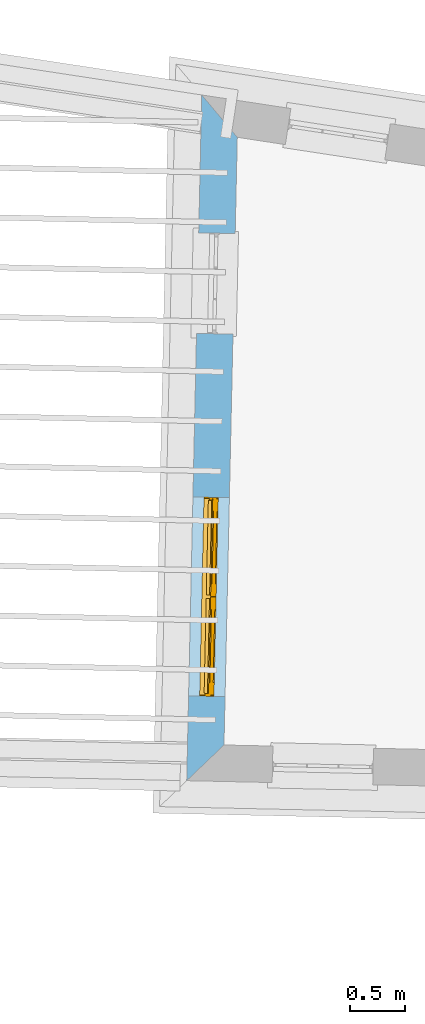
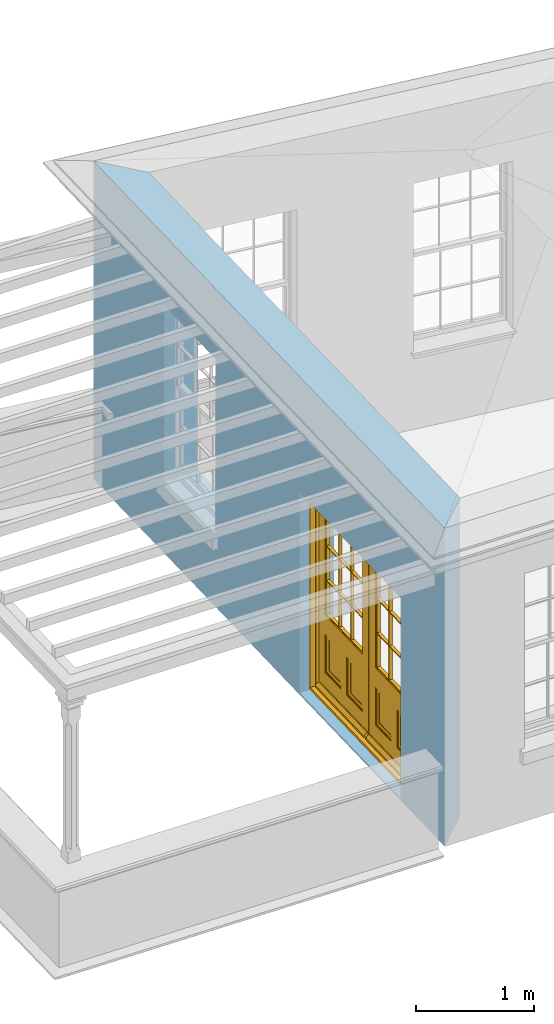
# One storey, part 4 of 12: 1 door, 2 openings, plus 1 element that does not belong to this part.
"""IFC2X3 building model written with IfcOpenShell, lengths in metres."""

from ifc_helpers import new_model, si_unit, frame, origin, place, context, subcontext, project, spatial, polyline, outline, extrude, faceted_brep, material, layer, layer_set, layer_usage, element, fill, save


model = new_model("IFC2X3")

# Units and contexts
model_context = context("Model", 3, world=origin())
body_context = subcontext(model_context, "Body", "Model", "MODEL_VIEW")
ifc_project = project(units=[si_unit("PLANEANGLEUNIT", "RADIAN"), si_unit("MASSUNIT", "GRAM", prefix="KILO"), si_unit("FORCEUNIT", "NEWTON", prefix="KILO"), si_unit("LENGTHUNIT", "METRE")], contexts=[model_context])

# Site, building, storey
site_placement = place(None, origin())
site = spatial("IfcSite", under=ifc_project, at=site_placement, CompositionType="ELEMENT")
building_placement = place(None, origin())
building = spatial("IfcBuilding", under=site, at=building_placement, Name="Building plot-18", CompositionType="ELEMENT")
storey_placement = place(None, frame((0.0, 0.0, 9.9)))
storey = spatial("IfcBuildingStorey", under=building, at=storey_placement, Name="Floor 2", CompositionType="ELEMENT", Elevation=9.9)

# Wall, openings, door
ifc_material = material(Name="Masonry")
ifc_layer = layer(ifc_material, 0.33, ventilated=False)
ifc_layer_set = layer_set([ifc_layer], Name="My Wall")
ifc_layer_usage = layer_usage(ifc_layer_set, "AXIS2", "NEGATIVE", 0.08)
wall_placement = place(storey_placement, origin())
wall = element("IfcWallStandardCase", 1, at=wall_placement, inside=storey, material=ifc_layer_usage, Name="exterior", context=body_context, shape_type="SweptSolid", body=[
    extrude(outline(polyline([(90.2260155594004, 26.2254654944291), (89.9043108567451, 26.6083343363116), (89.7686586524696, 20.406326207039), (90.1057958794453, 20.7290311654569), (90.2260155594004, 26.2254654944291)])), origin(), (0.0, 0.0, 1.0), 3.3),
])
opening_1_placement = place(storey_placement, frame((0.0, 0.0, 0.75)))
element("IfcOpeningElement", 2, at=opening_1_placement, cuts=wall, Name="Opening", ObjectType="Opening", context=body_context, shape_type="SweptSolid", body=[
    extrude(outline(polyline([(89.8770456128179, 25.3617695245838), (89.8571465758663, 24.451987117451), (90.1870676685628, 24.4447709831718), (90.2069667055144, 25.3545533903047), (89.8770456128179, 25.3617695245838)])), origin(), (0.0, 0.0, 1.0), 1.82),
])
opening_2_placement = place(storey_placement, frame((0.0, 0.0, 0.0199999999999996)))
opening_2 = element("IfcOpeningElement", 3, at=opening_2_placement, cuts=wall, Name="Opening", ObjectType="Opening", context=body_context, shape_type="SweptSolid", body=[
    extrude(outline(polyline([(89.8247960115718, 22.9729218577882), (89.7854352791401, 21.1733522612618), (90.1153563718366, 21.1661361269826), (90.1547171042684, 22.9657057235091), (89.8247960115718, 22.9729218577882)])), origin(), (0.0, 0.0, 1.0), 2.08),
])
door_placement = place(storey_placement, frame((90.0747362333116, 22.9674550893949, 0.0199999999999996), z_axis=(0.0, 0.0, 1.0), x_axis=(-0.03936073243176, -1.79956959652647, 0.0)))
door = element("IfcDoor", 4, at=door_placement, inside=storey, Name="living outside door", OverallHeight=2.08, OverallWidth=1.8, context=body_context, shape_type="Brep", held_by="IfcProductRepresentation", body=[
    faceted_brep([(0.545, -0.055, 0.265), (0.745, -0.055, 0.265), (0.745, -0.05, 0.265), (0.545, -0.05, 0.265), (0.745, -0.05, 0.58), (0.545, -0.05, 0.58), (0.545, -0.055, 0.58), (0.515, -0.06, 0.235), (0.775, -0.06, 0.235), (0.745, -0.055, 0.58), (0.515, -0.06, 0.61), (0.515, -0.065, 0.235), (0.775, -0.065, 0.235), (0.775, -0.06, 0.61), (0.515, -0.065, 0.61), (0.785, -0.065, 0.225), (0.505, -0.065, 0.225), (0.775, -0.065, 0.61), (0.505, -0.065, 0.62), (0.785, -0.065, 0.62), (0.505, -0.07, 0.225), (0.785, -0.07, 0.225), (0.505, -0.07, 0.62), (0.785, -0.07, 0.62), (0.883, -0.07, 0.075), (0.898, -0.07, 0.075), (0.405, -0.07, 0.62), (0.405, -0.07, 0.225), (0.027, -0.07, 0.075), (0.785, -0.07, 0.82), (0.125, -0.07, 0.82), (0.405, -0.065, 0.62), (0.405, -0.065, 0.225), (0.898, -0.07, 2.068), (0.027, -0.08, 0.075), (0.883, -0.08, 0.075), (0.125, -0.07, 0.225), (0.012, -0.07, 0.075), (0.785, -0.06, 0.82), (0.125, -0.06, 0.82), (0.125, -0.07, 0.62), (0.125, -0.065, 0.62), (0.395, -0.065, 0.61), (0.395, -0.065, 0.235), (0.125, -0.065, 0.225), (0.785, -0.07, 1.895), (0.027, -0.11, 0.045), (0.883, -0.11, 0.045), (0.558333, -0.06, 0.83), (0.351667, -0.06, 0.83), (0.125, -0.07, 1.895), (0.125, -0.06, 1.895), (0.785, -0.06, 1.895), (0.012, -0.07, 2.068), (0.135, -0.065, 0.61), (0.395, -0.06, 0.61), (0.395, -0.06, 0.235), (0.135, -0.065, 0.235), (0.027, -0.11, 0.027), (0.883, -0.11, 0.027), (0.568333, -0.06, 0.83), (0.558333, -0.03, 0.83), (0.351667, -0.03, 0.83), (0.341667, -0.06, 0.83), (0.135, -0.06, 1.185), (0.135, -0.06, 1.53), (0.775, -0.06, 1.53), (0.775, -0.06, 1.185), (0.135, -0.06, 0.61), (0.365, -0.055, 0.58), (0.365, -0.055, 0.265), (0.135, -0.06, 0.235), (0.568333, -0.06, 1.175), (0.558333, -0.06, 1.175), (0.775, -0.06, 0.83), (0.558333, -0.03, 1.175), (0.785, -0.03, 0.82), (0.125, -0.03, 0.82), (0.351667, -0.03, 1.175), (0.351667, -0.06, 1.175), (0.341667, -0.06, 1.175), (0.135, -0.06, 0.83), (0.135, -0.06, 1.175), (0.135, -0.03, 1.185), (0.135, -0.03, 1.53), (0.135, -0.06, 1.54), (0.351667, -0.06, 1.885), (0.558333, -0.06, 1.885), (0.775, -0.03, 1.53), (0.775, -0.03, 1.185), (0.775, -0.06, 1.175), (0.775, -0.06, 1.54), (0.165, -0.055, 0.58), (0.365, -0.05, 0.58), (0.365, -0.05, 0.265), (0.165, -0.055, 0.265), (0.568333, -0.03, 0.83), (0.568333, -0.03, 1.175), (0.568333, -0.06, 1.185), (0.558333, -0.06, 1.185), (0.775, -0.03, 0.83), (0.785, -0.02, 0.82), (0.125, -0.02, 0.82), (0.341667, -0.03, 0.83), (0.341667, -0.03, 1.175), (0.351667, -0.06, 1.185), (0.341667, -0.06, 1.185), (0.135, -0.03, 0.83), (0.341667, -0.03, 1.185), (0.125, -0.03, 1.895), (0.341667, -0.03, 1.53), (0.341667, -0.06, 1.53), (0.135, -0.06, 1.885), (0.341667, -0.06, 1.54), (0.341667, -0.06, 1.885), (0.558333, -0.03, 1.885), (0.351667, -0.03, 1.885), (0.568333, -0.06, 1.885), (0.785, -0.03, 1.895), (0.568333, -0.03, 1.185), (0.568333, -0.06, 1.53), (0.568333, -0.03, 1.53), (0.568333, -0.06, 1.54), (0.775, -0.06, 1.885), (0.165, -0.05, 0.58), (0.165, -0.05, 0.265), (0.775, -0.03, 1.175), (0.558333, -0.06, 1.53), (0.351667, -0.03, 1.185), (0.558333, -0.03, 1.185), (0.505, -0.02, 0.62), (0.405, -0.02, 0.62), (0.125, -0.02, 1.895), (0.785, -0.02, 1.895), (0.351667, -0.06, 1.53), (0.135, -0.03, 1.175), (0.135, -0.03, 1.54), (0.341667, -0.03, 1.54), (0.135, -0.03, 1.885), (0.351667, -0.06, 1.54), (0.558333, -0.03, 1.54), (0.558333, -0.06, 1.54), (0.351667, -0.03, 1.54), (0.775, -0.03, 1.54), (0.568333, -0.03, 1.54), (0.775, -0.03, 1.885), (0.558333, -0.03, 1.53), (0.405, -0.02, 0.225), (0.505, -0.02, 0.225), (0.125, -0.02, 0.62), (0.785, -0.02, 0.62), (0.012, -0.02, 2.068), (0.898, -0.02, 2.068), (0.351667, -0.03, 1.53), (0.341667, -0.03, 1.885), (0.568333, -0.03, 1.885), (0.405, -0.025, 0.225), (0.405, -0.025, 0.62), (0.505, -0.025, 0.62), (0.505, -0.025, 0.225), (0.898, -0.02, 0.027), (0.012, -0.02, 0.027), (0.125, -0.025, 0.62), (0.785, -0.025, 0.62), (0.395, -0.025, 0.235), (0.395, -0.025, 0.61), (0.125, -0.02, 0.225), (0.125, -0.025, 0.225), (0.515, -0.025, 0.61), (0.515, -0.025, 0.235), (0.785, -0.02, 0.225), (0.785, -0.025, 0.225), (0.135, -0.025, 0.61), (0.775, -0.025, 0.61), (0.135, -0.025, 0.235), (0.395, -0.03, 0.235), (0.395, -0.03, 0.61), (0.515, -0.03, 0.61), (0.515, -0.03, 0.235), (0.775, -0.025, 0.235), (0.135, -0.03, 0.61), (0.775, -0.03, 0.61), (0.135, -0.03, 0.235), (0.365, -0.035, 0.265), (0.365, -0.035, 0.58), (0.545, -0.035, 0.58), (0.545, -0.035, 0.265), (0.775, -0.03, 0.235), (0.165, -0.035, 0.58), (0.745, -0.035, 0.58), (0.165, -0.035, 0.265), (0.365, -0.04, 0.58), (0.365, -0.04, 0.265), (0.545, -0.04, 0.58), (0.545, -0.04, 0.265), (0.745, -0.035, 0.265), (0.165, -0.04, 0.58), (0.745, -0.04, 0.58), (0.165, -0.04, 0.265), (0.745, -0.04, 0.265), (1.775, -0.072, 0.025), (0.025, -0.072, 0.025), (0.025, -0.1, 0.025), (1.775, -0.1, 0.025), (1.79, -0.02, 0.025), (0.01, -0.02, 0.025), (1.79, -0.072, 0.025), (1.8, -0.02, 0.0), (0.0, -0.02, 0.0), (0.01, -0.072, 0.025), (1.79, -0.072, 2.07), (1.79, -0.02, 2.07), (1.775, -0.072, 2.055), (1.8, -0.02, 2.08), (0.01, -0.02, 2.07), (0.0, -0.02, 2.08), (0.01, -0.072, 2.07), (0.025, -0.072, 2.055), (0.0, -0.15, 2.08), (1.8, -0.15, 2.08), (0.01, -0.15, 2.07), (1.79, -0.15, 2.07), (0.01, -0.1, 2.07), (1.79, -0.1, 2.07), (0.0, -0.15, 0.0), (1.8, -0.15, 0.0), (0.01, -0.15, 0.025), (1.79, -0.15, 0.025), (0.01, -0.1, 0.025), (0.025, -0.1, 2.055), (1.79, -0.1, 0.025), (1.775, -0.1, 2.055), (0.898, -0.07, 0.027), (0.012, -0.07, 0.027), (0.883, -0.07, 0.027), (0.027, -0.07, 0.027), (1.435, -0.055, 0.265), (1.635, -0.055, 0.265), (1.635, -0.05, 0.265), (1.435, -0.05, 0.265), (1.635, -0.05, 0.58), (1.435, -0.05, 0.58), (1.435, -0.055, 0.58), (1.405, -0.06, 0.235), (1.665, -0.06, 0.235), (1.635, -0.055, 0.58), (1.405, -0.06, 0.61), (1.405, -0.065, 0.235), (1.665, -0.065, 0.235), (1.665, -0.06, 0.61), (1.405, -0.065, 0.61), (1.675, -0.065, 0.225), (1.395, -0.065, 0.225), (1.665, -0.065, 0.61), (1.395, -0.065, 0.62), (1.675, -0.065, 0.62), (1.395, -0.07, 0.225), (1.675, -0.07, 0.225), (1.395, -0.07, 0.62), (1.675, -0.07, 0.62), (1.773, -0.07, 0.075), (1.788, -0.07, 0.075), (1.295, -0.07, 0.62), (1.295, -0.07, 0.225), (0.917, -0.07, 0.075), (1.675, -0.07, 0.82), (1.015, -0.07, 0.82), (1.295, -0.065, 0.62), (1.295, -0.065, 0.225), (1.788, -0.07, 2.068), (0.917, -0.08, 0.075), (1.773, -0.08, 0.075), (1.015, -0.07, 0.225), (0.902, -0.07, 0.075), (1.675, -0.06, 0.82), (1.015, -0.06, 0.82), (1.015, -0.07, 0.62), (1.015, -0.065, 0.62), (1.285, -0.065, 0.61), (1.285, -0.065, 0.235), (1.015, -0.065, 0.225), (1.675, -0.07, 1.895), (0.917, -0.11, 0.045), (1.773, -0.11, 0.045), (1.448333, -0.06, 0.83), (1.241667, -0.06, 0.83), (1.015, -0.07, 1.895), (1.015, -0.06, 1.895), (1.675, -0.06, 1.895), (0.902, -0.07, 2.068), (1.025, -0.065, 0.61), (1.285, -0.06, 0.61), (1.285, -0.06, 0.235), (1.025, -0.065, 0.235), (0.917, -0.11, 0.027), (1.773, -0.11, 0.027), (1.458333, -0.06, 0.83), (1.448333, -0.03, 0.83), (1.241667, -0.03, 0.83), (1.231667, -0.06, 0.83), (1.025, -0.06, 1.185), (1.025, -0.06, 1.53), (1.665, -0.06, 1.53), (1.665, -0.06, 1.185), (1.025, -0.06, 0.61), (1.255, -0.055, 0.58), (1.255, -0.055, 0.265), (1.025, -0.06, 0.235), (1.458333, -0.06, 1.175), (1.448333, -0.06, 1.175), (1.665, -0.06, 0.83), (1.448333, -0.03, 1.175), (1.675, -0.03, 0.82), (1.015, -0.03, 0.82), (1.241667, -0.03, 1.175), (1.241667, -0.06, 1.175), (1.231667, -0.06, 1.175), (1.025, -0.06, 0.83), (1.025, -0.06, 1.175), (1.025, -0.03, 1.185), (1.025, -0.03, 1.53), (1.025, -0.06, 1.54), (1.241667, -0.06, 1.885), (1.448333, -0.06, 1.885), (1.665, -0.03, 1.53), (1.665, -0.03, 1.185), (1.665, -0.06, 1.175), (1.665, -0.06, 1.54), (1.055, -0.055, 0.58), (1.255, -0.05, 0.58), (1.255, -0.05, 0.265), (1.055, -0.055, 0.265), (1.458333, -0.03, 0.83), (1.458333, -0.03, 1.175), (1.458333, -0.06, 1.185), (1.448333, -0.06, 1.185), (1.665, -0.03, 0.83), (1.675, -0.02, 0.82), (1.015, -0.02, 0.82), (1.231667, -0.03, 0.83), (1.231667, -0.03, 1.175), (1.241667, -0.06, 1.185), (1.231667, -0.06, 1.185), (1.025, -0.03, 0.83), (1.231667, -0.03, 1.185), (1.015, -0.03, 1.895), (1.231667, -0.03, 1.53), (1.231667, -0.06, 1.53), (1.025, -0.06, 1.885), (1.231667, -0.06, 1.54), (1.231667, -0.06, 1.885), (1.448333, -0.03, 1.885), (1.241667, -0.03, 1.885), (1.458333, -0.06, 1.885), (1.675, -0.03, 1.895), (1.458333, -0.03, 1.185), (1.458333, -0.06, 1.53), (1.458333, -0.03, 1.53), (1.458333, -0.06, 1.54), (1.665, -0.06, 1.885), (1.055, -0.05, 0.58), (1.055, -0.05, 0.265), (1.665, -0.03, 1.175), (1.448333, -0.06, 1.53), (1.241667, -0.03, 1.185), (1.448333, -0.03, 1.185), (1.395, -0.02, 0.62), (1.295, -0.02, 0.62), (1.015, -0.02, 1.895), (1.675, -0.02, 1.895), (1.241667, -0.06, 1.53), (1.025, -0.03, 1.175), (1.025, -0.03, 1.54), (1.231667, -0.03, 1.54), (1.025, -0.03, 1.885), (1.241667, -0.06, 1.54), (1.448333, -0.03, 1.54), (1.448333, -0.06, 1.54), (1.241667, -0.03, 1.54), (1.665, -0.03, 1.54), (1.458333, -0.03, 1.54), (1.665, -0.03, 1.885), (1.448333, -0.03, 1.53), (1.295, -0.02, 0.225), (1.395, -0.02, 0.225), (1.015, -0.02, 0.62), (1.675, -0.02, 0.62), (0.902, -0.02, 2.068), (1.788, -0.02, 2.068), (1.241667, -0.03, 1.53), (1.231667, -0.03, 1.885), (1.458333, -0.03, 1.885), (1.295, -0.025, 0.225), (1.295, -0.025, 0.62), (1.395, -0.025, 0.62), (1.395, -0.025, 0.225), (1.788, -0.02, 0.027), (0.902, -0.02, 0.027), (1.015, -0.025, 0.62), (1.675, -0.025, 0.62), (1.285, -0.025, 0.235), (1.285, -0.025, 0.61), (1.015, -0.02, 0.225), (1.015, -0.025, 0.225), (1.405, -0.025, 0.61), (1.405, -0.025, 0.235), (1.675, -0.02, 0.225), (1.675, -0.025, 0.225), (1.025, -0.025, 0.61), (1.665, -0.025, 0.61), (1.025, -0.025, 0.235), (1.285, -0.03, 0.235), (1.285, -0.03, 0.61), (1.405, -0.03, 0.61), (1.405, -0.03, 0.235), (1.665, -0.025, 0.235), (1.025, -0.03, 0.61), (1.665, -0.03, 0.61), (1.025, -0.03, 0.235), (1.255, -0.035, 0.265), (1.255, -0.035, 0.58), (1.435, -0.035, 0.58), (1.435, -0.035, 0.265), (1.665, -0.03, 0.235), (1.055, -0.035, 0.58), (1.635, -0.035, 0.58), (1.055, -0.035, 0.265), (1.255, -0.04, 0.58), (1.255, -0.04, 0.265), (1.435, -0.04, 0.58), (1.435, -0.04, 0.265), (1.635, -0.035, 0.265), (1.055, -0.04, 0.58), (1.635, -0.04, 0.58), (1.055, -0.04, 0.265), (1.635, -0.04, 0.265), (1.788, -0.07, 0.027), (0.902, -0.07, 0.027), (1.773, -0.07, 0.027), (0.917, -0.07, 0.027)], [[[0, 1, 2, 3]], [[2, 4, 5, 3]], [[0, 3, 5, 6]], [[1, 0, 7, 8]], [[9, 4, 2, 1]], [[9, 6, 5, 4]], [[0, 6, 10, 7]], [[8, 7, 11, 12]], [[8, 13, 9, 1]], [[13, 10, 6, 9]], [[7, 10, 14, 11]], [[15, 12, 11, 16]], [[12, 17, 13, 8]], [[17, 14, 10, 13]], [[18, 16, 11, 14]], [[15, 19, 17, 12]], [[15, 16, 20, 21]], [[14, 17, 19, 18]], [[16, 18, 22, 20]], [[21, 23, 19, 15]], [[24, 25, 21, 20]], [[23, 22, 18, 19]], [[20, 22, 26, 27]], [[23, 21, 25]], [[28, 24, 20, 27]], [[22, 23, 29]], [[29, 30, 26, 22]], [[27, 26, 31, 32]], [[23, 25, 33, 29]], [[34, 35, 24, 28]], [[28, 27, 36, 37]], [[38, 39, 30, 29]], [[26, 30, 40]], [[26, 40, 41, 31]], [[42, 43, 32, 31]], [[32, 44, 36, 27]], [[33, 45, 29]], [[46, 47, 35, 34]], [[36, 40, 37]], [[39, 38, 48, 49]], [[50, 30, 39, 51]], [[29, 45, 52, 38]], [[53, 37, 40, 30]], [[44, 41, 40, 36]], [[31, 41, 54, 42]], [[43, 42, 55, 56]], [[57, 44, 32, 43]], [[50, 45, 33, 53]], [[47, 46, 58, 59]], [[60, 48, 38]], [[49, 48, 61, 62]], [[49, 63, 39]], [[50, 53, 30]], [[51, 39, 64, 65]], [[45, 50, 51, 52]], [[66, 67, 38, 52]], [[57, 54, 41, 44]], [[42, 54, 68, 55]], [[56, 55, 69, 70]], [[56, 71, 57, 43]], [[60, 72, 73, 48]], [[60, 38, 74]], [[48, 73, 75, 61]], [[76, 77, 62, 61]], [[62, 78, 79, 49]], [[49, 79, 80, 63]], [[63, 81, 39]], [[82, 64, 39]], [[65, 64, 83, 84]], [[85, 51, 65]], [[52, 51, 86, 87]], [[88, 89, 67, 66]], [[90, 38, 67]], [[91, 66, 52]], [[71, 68, 54, 57]], [[55, 68, 92, 69]], [[69, 93, 94, 70]], [[70, 95, 71, 56]], [[96, 97, 72, 60]], [[73, 72, 98, 99]], [[74, 38, 90]], [[100, 96, 60, 74]], [[75, 73, 79, 78]], [[61, 75, 97, 96]], [[101, 102, 77, 76]], [[77, 103, 62]], [[96, 76, 61]], [[103, 104, 78, 62]], [[80, 79, 105, 106]], [[63, 80, 104, 103]], [[81, 63, 103, 107]], [[81, 82, 39]], [[106, 64, 82, 80]], [[106, 108, 83, 64]], [[84, 83, 77, 109]], [[110, 111, 65, 84]], [[112, 51, 85]], [[113, 85, 65, 111]], [[114, 86, 51]], [[115, 87, 86, 116]], [[117, 52, 87]], [[118, 76, 89, 88]], [[119, 98, 67, 89]], [[120, 121, 88, 66]], [[67, 98, 72, 90]], [[91, 122, 120, 66]], [[91, 52, 123]], [[95, 92, 68, 71]], [[69, 92, 124, 93]], [[94, 93, 124, 125]], [[94, 125, 95, 70]], [[72, 97, 126, 90]], [[127, 99, 98, 120]], [[99, 105, 79, 73]], [[74, 90, 126, 100]], [[96, 100, 76]], [[128, 129, 75, 78]], [[97, 75, 129, 119]], [[130, 131, 102, 101]], [[109, 77, 102, 132]], [[133, 101, 76, 118]], [[77, 107, 103]], [[78, 104, 108, 128]], [[111, 106, 105, 134]], [[104, 80, 82, 135]], [[107, 135, 82, 81]], [[110, 108, 106, 111]], [[104, 135, 83, 108]], [[83, 135, 77]], [[136, 84, 109]], [[110, 84, 136, 137]], [[114, 51, 112]], [[85, 136, 138, 112]], [[113, 137, 136, 85]], [[111, 134, 139, 113]], [[86, 114, 113, 139]], [[140, 141, 87, 115]], [[139, 142, 116, 86]], [[109, 118, 115, 116]], [[117, 123, 52]], [[117, 87, 141, 122]], [[126, 89, 76]], [[143, 118, 88]], [[120, 98, 119, 121]], [[119, 89, 126, 97]], [[144, 143, 88, 121]], [[144, 122, 91, 143]], [[127, 120, 122, 141]], [[143, 91, 123, 145]], [[124, 92, 95, 125]], [[146, 129, 99, 127]], [[99, 129, 128, 105]], [[100, 126, 76]], [[121, 119, 129, 146]], [[147, 131, 130, 148]], [[131, 149, 102]], [[130, 101, 150]], [[102, 151, 132]], [[118, 109, 132, 133]], [[101, 133, 152]], [[107, 77, 135]], [[153, 128, 108, 110]], [[134, 105, 128, 153]], [[109, 138, 136]], [[153, 110, 137, 142]], [[154, 114, 112, 138]], [[137, 113, 114, 154]], [[141, 139, 134, 127]], [[141, 140, 142, 139]], [[144, 140, 115, 155]], [[142, 137, 154, 116]], [[155, 115, 118]], [[116, 154, 109]], [[117, 155, 145, 123]], [[122, 144, 155, 117]], [[143, 145, 118]], [[121, 146, 140, 144]], [[146, 127, 134, 153]], [[156, 157, 131, 147]], [[148, 130, 158, 159]], [[148, 160, 161, 147]], [[157, 162, 149, 131]], [[161, 151, 102, 149]], [[101, 152, 160, 150]], [[163, 158, 130, 150]], [[151, 152, 133, 132]], [[154, 138, 109]], [[142, 140, 146, 153]], [[145, 155, 118]], [[157, 156, 164, 165]], [[147, 166, 167, 156]], [[168, 169, 159, 158]], [[170, 148, 159, 171]], [[148, 170, 160]], [[166, 147, 161]], [[172, 162, 157, 165]], [[166, 149, 162, 167]], [[166, 161, 149]], [[150, 160, 170]], [[163, 173, 168, 158]], [[171, 163, 150, 170]], [[174, 164, 156, 167]], [[175, 176, 165, 164]], [[169, 168, 177, 178]], [[171, 159, 169, 179]], [[167, 162, 172, 174]], [[176, 180, 172, 165]], [[179, 173, 163, 171]], [[181, 177, 168, 173]], [[164, 174, 182, 175]], [[183, 184, 176, 175]], [[178, 177, 185, 186]], [[179, 169, 178, 187]], [[174, 172, 180, 182]], [[184, 188, 180, 176]], [[187, 181, 173, 179]], [[189, 185, 177, 181]], [[175, 182, 190, 183]], [[191, 184, 183, 192]], [[185, 193, 194, 186]], [[187, 178, 186, 195]], [[182, 180, 188, 190]], [[191, 196, 188, 184]], [[195, 189, 181, 187]], [[197, 193, 185, 189]], [[183, 190, 198, 192]], [[198, 196, 191, 192]], [[194, 193, 197, 199]], [[195, 186, 194, 199]], [[188, 196, 198, 190]], [[197, 189, 195, 199]], [[200, 201, 202, 203]], [[201, 200, 204, 205]], [[206, 204, 200]], [[204, 207, 208, 205]], [[209, 201, 205]], [[210, 211, 204, 206]], [[206, 200, 212, 210]], [[211, 213, 207, 204]], [[214, 205, 208, 215]], [[216, 217, 201, 209]], [[205, 214, 216, 209]], [[216, 214, 211, 210]], [[210, 212, 217, 216]], [[214, 215, 213, 211]], [[218, 219, 213, 215]], [[219, 218, 220, 221]], [[221, 220, 222, 223]], [[215, 208, 224, 218]], [[225, 224, 208, 207]], [[224, 226, 220, 218]], [[224, 225, 227, 226]], [[219, 225, 207, 213]], [[228, 222, 220, 226]], [[219, 221, 227, 225]], [[226, 227, 203, 202]], [[202, 229, 222, 228]], [[228, 226, 202]], [[227, 221, 223, 230]], [[230, 203, 227]], [[217, 229, 202, 201]], [[231, 223, 222, 229]], [[230, 223, 231, 203]], [[231, 229, 217, 212]], [[212, 200, 203, 231]], [[33, 152, 151, 53]], [[25, 160, 152, 33]], [[161, 37, 53, 151]], [[232, 160, 25]], [[161, 233, 37]], [[160, 232, 234]], [[24, 234, 232, 25]], [[233, 161, 235]], [[37, 233, 235, 28]], [[161, 160, 234, 235]], [[35, 47, 234, 24]], [[28, 235, 46, 34]], [[58, 235, 234, 59]], [[59, 234, 47]], [[58, 46, 235]], [[236, 237, 238, 239]], [[238, 240, 241, 239]], [[236, 239, 241, 242]], [[237, 236, 243, 244]], [[245, 240, 238, 237]], [[245, 242, 241, 240]], [[236, 242, 246, 243]], [[244, 243, 247, 248]], [[244, 249, 245, 237]], [[249, 246, 242, 245]], [[243, 246, 250, 247]], [[251, 248, 247, 252]], [[248, 253, 249, 244]], [[253, 250, 246, 249]], [[254, 252, 247, 250]], [[251, 255, 253, 248]], [[251, 252, 256, 257]], [[250, 253, 255, 254]], [[252, 254, 258, 256]], [[257, 259, 255, 251]], [[260, 261, 257, 256]], [[259, 258, 254, 255]], [[256, 258, 262, 263]], [[259, 257, 261]], [[264, 260, 256, 263]], [[258, 259, 265]], [[265, 266, 262, 258]], [[263, 262, 267, 268]], [[259, 261, 269, 265]], [[270, 271, 260, 264]], [[264, 263, 272, 273]], [[274, 275, 266, 265]], [[262, 266, 276]], [[262, 276, 277, 267]], [[278, 279, 268, 267]], [[268, 280, 272, 263]], [[269, 281, 265]], [[282, 283, 271, 270]], [[272, 276, 273]], [[275, 274, 284, 285]], [[286, 266, 275, 287]], [[265, 281, 288, 274]], [[289, 273, 276, 266]], [[280, 277, 276, 272]], [[267, 277, 290, 278]], [[279, 278, 291, 292]], [[293, 280, 268, 279]], [[286, 281, 269, 289]], [[283, 282, 294, 295]], [[296, 284, 274]], [[285, 284, 297, 298]], [[285, 299, 275]], [[286, 289, 266]], [[287, 275, 300, 301]], [[281, 286, 287, 288]], [[302, 303, 274, 288]], [[293, 290, 277, 280]], [[278, 290, 304, 291]], [[292, 291, 305, 306]], [[292, 307, 293, 279]], [[296, 308, 309, 284]], [[296, 274, 310]], [[284, 309, 311, 297]], [[312, 313, 298, 297]], [[298, 314, 315, 285]], [[285, 315, 316, 299]], [[299, 317, 275]], [[318, 300, 275]], [[301, 300, 319, 320]], [[321, 287, 301]], [[288, 287, 322, 323]], [[324, 325, 303, 302]], [[326, 274, 303]], [[327, 302, 288]], [[307, 304, 290, 293]], [[291, 304, 328, 305]], [[305, 329, 330, 306]], [[306, 331, 307, 292]], [[332, 333, 308, 296]], [[309, 308, 334, 335]], [[310, 274, 326]], [[336, 332, 296, 310]], [[311, 309, 315, 314]], [[297, 311, 333, 332]], [[337, 338, 313, 312]], [[313, 339, 298]], [[332, 312, 297]], [[339, 340, 314, 298]], [[316, 315, 341, 342]], [[299, 316, 340, 339]], [[317, 299, 339, 343]], [[317, 318, 275]], [[342, 300, 318, 316]], [[342, 344, 319, 300]], [[320, 319, 313, 345]], [[346, 347, 301, 320]], [[348, 287, 321]], [[349, 321, 301, 347]], [[350, 322, 287]], [[351, 323, 322, 352]], [[353, 288, 323]], [[354, 312, 325, 324]], [[355, 334, 303, 325]], [[356, 357, 324, 302]], [[303, 334, 308, 326]], [[327, 358, 356, 302]], [[327, 288, 359]], [[331, 328, 304, 307]], [[305, 328, 360, 329]], [[330, 329, 360, 361]], [[330, 361, 331, 306]], [[308, 333, 362, 326]], [[363, 335, 334, 356]], [[335, 341, 315, 309]], [[310, 326, 362, 336]], [[332, 336, 312]], [[364, 365, 311, 314]], [[333, 311, 365, 355]], [[366, 367, 338, 337]], [[345, 313, 338, 368]], [[369, 337, 312, 354]], [[313, 343, 339]], [[314, 340, 344, 364]], [[347, 342, 341, 370]], [[340, 316, 318, 371]], [[343, 371, 318, 317]], [[346, 344, 342, 347]], [[340, 371, 319, 344]], [[319, 371, 313]], [[372, 320, 345]], [[346, 320, 372, 373]], [[350, 287, 348]], [[321, 372, 374, 348]], [[349, 373, 372, 321]], [[347, 370, 375, 349]], [[322, 350, 349, 375]], [[376, 377, 323, 351]], [[375, 378, 352, 322]], [[345, 354, 351, 352]], [[353, 359, 288]], [[353, 323, 377, 358]], [[362, 325, 312]], [[379, 354, 324]], [[356, 334, 355, 357]], [[355, 325, 362, 333]], [[380, 379, 324, 357]], [[380, 358, 327, 379]], [[363, 356, 358, 377]], [[379, 327, 359, 381]], [[360, 328, 331, 361]], [[382, 365, 335, 363]], [[335, 365, 364, 341]], [[336, 362, 312]], [[357, 355, 365, 382]], [[383, 367, 366, 384]], [[367, 385, 338]], [[366, 337, 386]], [[338, 387, 368]], [[354, 345, 368, 369]], [[337, 369, 388]], [[343, 313, 371]], [[389, 364, 344, 346]], [[370, 341, 364, 389]], [[345, 374, 372]], [[389, 346, 373, 378]], [[390, 350, 348, 374]], [[373, 349, 350, 390]], [[377, 375, 370, 363]], [[377, 376, 378, 375]], [[380, 376, 351, 391]], [[378, 373, 390, 352]], [[391, 351, 354]], [[352, 390, 345]], [[353, 391, 381, 359]], [[358, 380, 391, 353]], [[379, 381, 354]], [[357, 382, 376, 380]], [[382, 363, 370, 389]], [[392, 393, 367, 383]], [[384, 366, 394, 395]], [[384, 396, 397, 383]], [[393, 398, 385, 367]], [[397, 387, 338, 385]], [[337, 388, 396, 386]], [[399, 394, 366, 386]], [[387, 388, 369, 368]], [[390, 374, 345]], [[378, 376, 382, 389]], [[381, 391, 354]], [[393, 392, 400, 401]], [[383, 402, 403, 392]], [[404, 405, 395, 394]], [[406, 384, 395, 407]], [[384, 406, 396]], [[402, 383, 397]], [[408, 398, 393, 401]], [[402, 385, 398, 403]], [[402, 397, 385]], [[386, 396, 406]], [[399, 409, 404, 394]], [[407, 399, 386, 406]], [[410, 400, 392, 403]], [[411, 412, 401, 400]], [[405, 404, 413, 414]], [[407, 395, 405, 415]], [[403, 398, 408, 410]], [[412, 416, 408, 401]], [[415, 409, 399, 407]], [[417, 413, 404, 409]], [[400, 410, 418, 411]], [[419, 420, 412, 411]], [[414, 413, 421, 422]], [[415, 405, 414, 423]], [[410, 408, 416, 418]], [[420, 424, 416, 412]], [[423, 417, 409, 415]], [[425, 421, 413, 417]], [[411, 418, 426, 419]], [[427, 420, 419, 428]], [[421, 429, 430, 422]], [[423, 414, 422, 431]], [[418, 416, 424, 426]], [[427, 432, 424, 420]], [[431, 425, 417, 423]], [[433, 429, 421, 425]], [[419, 426, 434, 428]], [[434, 432, 427, 428]], [[430, 429, 433, 435]], [[431, 422, 430, 435]], [[424, 432, 434, 426]], [[433, 425, 431, 435]], [[269, 388, 387, 289]], [[261, 396, 388, 269]], [[397, 273, 289, 387]], [[436, 396, 261]], [[397, 437, 273]], [[396, 436, 438]], [[260, 438, 436, 261]], [[437, 397, 439]], [[273, 437, 439, 264]], [[397, 396, 438, 439]], [[271, 283, 438, 260]], [[264, 439, 282, 270]], [[294, 439, 438, 295]], [[295, 438, 283]], [[294, 282, 439]]]),
])
fill(opening_2, door)

save(model, "model.ifc")
